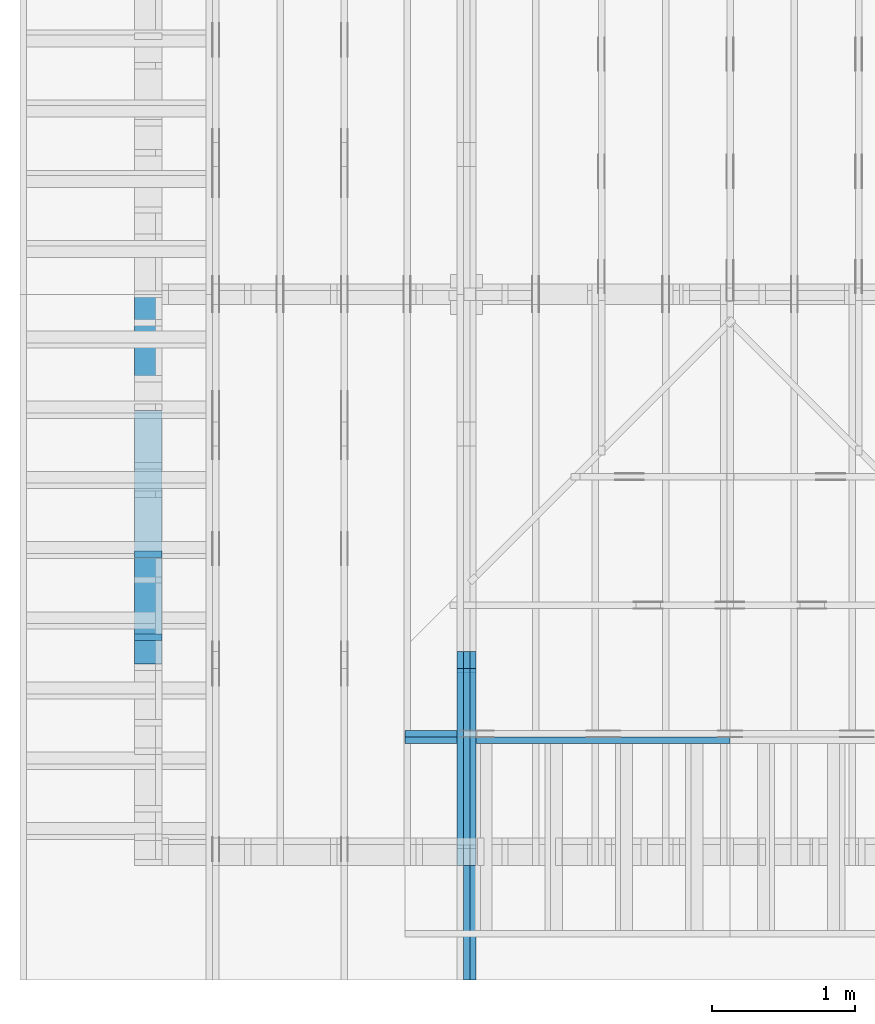
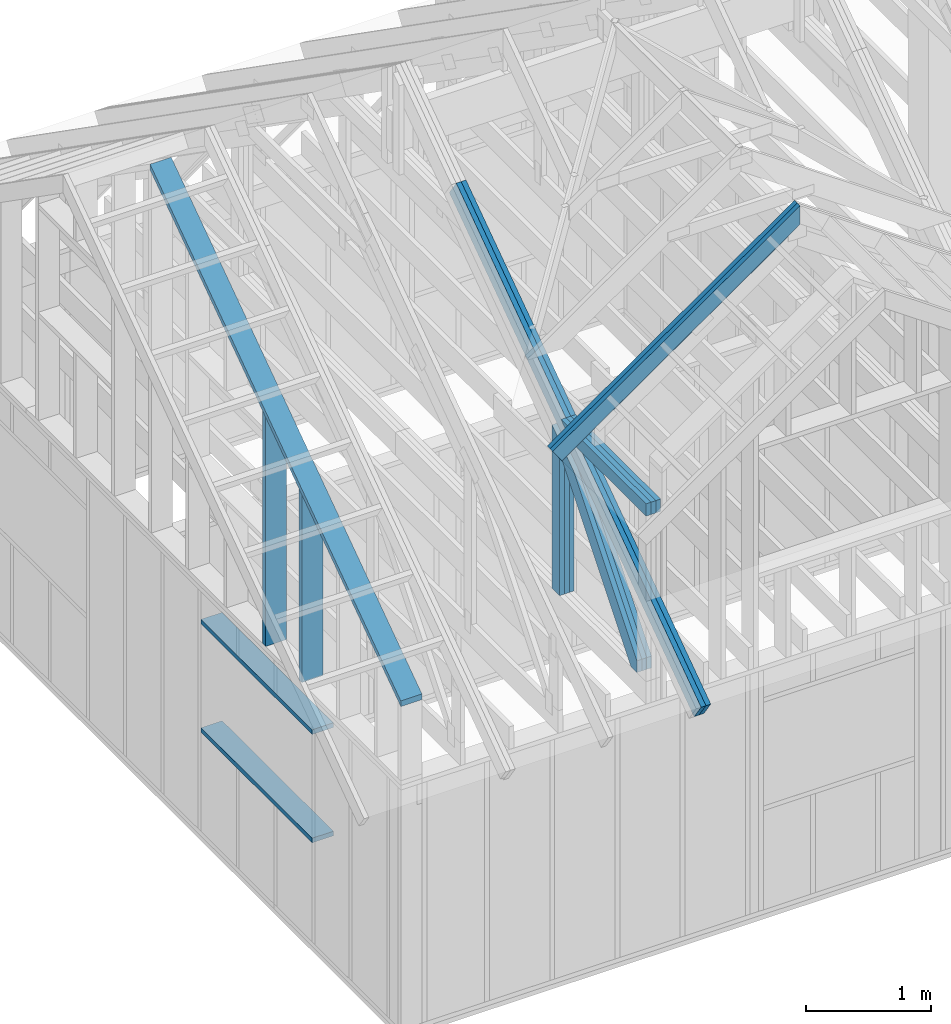
# One storey, part 4 of 70: 18 members, 5 elements without a shape of their own.
"""IFC2X3 building model written with IfcOpenShell, lengths in millimetres."""

from ifc_helpers import new_model, si_unit, frame, origin, origin_with_axes, origin_2d, place, context, project, spatial, faceted_brep, element, aggregate, save


model = new_model("IFC2X3")

# Units and contexts
model_context = context("Model", 3, precision=1e-05, world=origin())
plan_context = context("Plan", 2, precision=1e-05, world=origin_2d())
ifc_project = project(units=[si_unit("LENGTHUNIT", "METRE", prefix="MILLI"), si_unit("AREAUNIT", "SQUARE_METRE"), si_unit("VOLUMEUNIT", "CUBIC_METRE"), si_unit("SOLIDANGLEUNIT", "STERADIAN"), si_unit("PLANEANGLEUNIT", "RADIAN"), si_unit("MASSUNIT", "GRAM"), si_unit("TIMEUNIT", "SECOND"), si_unit("THERMODYNAMICTEMPERATUREUNIT", "DEGREE_CELSIUS"), si_unit("LUMINOUSINTENSITYUNIT", "LUMEN")], contexts=[model_context, plan_context])

# Site, building, storey
site_placement = place(None, origin_with_axes())
site = spatial("IfcSite", under=ifc_project, at=site_placement, CompositionType="ELEMENT")
building_placement = place(site_placement, origin_with_axes())
building = spatial("IfcBuilding", under=site, at=building_placement, Name="Layout 1", CompositionType="ELEMENT")
storey_placement = place(building_placement, origin_with_axes())
storey = spatial("IfcBuildingStorey", under=building, at=storey_placement, Name="Storey 1", CompositionType="ELEMENT", Elevation=0.0)

# Assembly, members
assembly_1_placement = place(storey_placement, frame((1969.9999999999982, 8000.000000000001, 1.1021457184401395e-14), z_axis=(-1.0, 1.836909530733566e-16, 6.123031769111886e-17), x_axis=(-1.836909530733566e-16, -1.0, 0.0)))
assembly_1 = element("IfcElementAssembly", 1, at=assembly_1_placement, inside=storey, Name="T11", AssemblyPlace="FACTORY", PredefinedType="TRUSS")
member_1_placement = place(assembly_1_placement, frame((4782.309641268, 3014.9999999994516, -135.0), z_axis=(0.0, 0.0, 1.0), x_axis=(0.8191520442889916, -0.5735764363510465, 0.0)))
member_1 = element("IfcMember", 2, at=member_1_placement, Name="T9", context=model_context, shape_type="Brep", body=[
    faceted_brep([(4768.153825500908, 195.00000000180353, 45.0), (1.6370904631912708e-10, 195.00000000180353, 45.0), (0.0, 1.8071659724228084e-09, 45.0), (4768.153825500287, 1.8071659724228084e-09, 45.0), (1.6370904631912708e-10, 195.00000000180353, 2.004791383006049e-26), (4768.153825500908, 195.00000000180353, 5.839111470710887e-13), (4768.153825500287, 1.8071659724228084e-09, 5.839111470710126e-13), (0.0, 1.8071659724228084e-09, 0.0), (-1.2523674699591298e-25, 1.8071659724228084e-09, 7.668285805162028e-42), (2.755364295975112e-15, 1.8071659724228084e-09, 45.0), (1.636957134777711e-10, 195.000000001015, 45.0), (1.63692958113475e-10, 195.000000001015, 9.850859431565386e-31), (4768.153825500287, -2.042652045517506e-12, 1.250722336794479e-28), (4768.153825500287, -2.039896681221406e-12, 45.0), (1.0454840658689129e-27, 1.8071687277871045e-09, 45.0), (0.0, 1.8071659724228084e-09, 0.0), (4768.153825500287, 195.00000000180353, -3.8067271842345146e-26), (4768.153825500287, 195.00000000180353, 45.0), (4768.153825500287, 0.0, 45.0), (4768.153825500287, 0.0, 0.0), (1.6370904631912708e-10, 195.000000001015, 0.0), (1.6370904631912708e-10, 195.000000001015, 45.0), (4768.153825500908, 195.00000000180347, 45.0), (4768.153825500908, 195.00000000180347, -4.733165431326071e-30)], [[[0, 1, 2, 3]], [[4, 5, 6, 7]], [[8, 9, 10, 11]], [[12, 13, 14, 15]], [[16, 17, 18, 19]], [[20, 21, 22, 23]]]),
])
member_2_placement = place(assembly_1_placement, frame((4782.309641268, 3014.9999999994516, -180.00000000000003), z_axis=(0.0, 0.0, 1.0), x_axis=(0.8191520442889916, -0.5735764363510465, 0.0)))
member_2 = element("IfcMember", 3, at=member_2_placement, Name="T9", context=model_context, shape_type="Brep", body=[
    faceted_brep([(4768.153825500908, 195.00000000180353, 45.0), (1.6370904631912708e-10, 195.00000000180353, 45.0), (0.0, 1.8071659724228084e-09, 45.0), (4768.153825500287, 1.8071659724228084e-09, 45.0), (1.6370904631912708e-10, 195.00000000180353, 2.004791383006049e-26), (4768.153825500908, 195.00000000180353, 5.839111470710887e-13), (4768.153825500287, 1.8071659724228084e-09, 5.839111470710126e-13), (0.0, 1.8071659724228084e-09, 0.0), (-1.2523674699591298e-25, 1.8071659724228084e-09, 7.668285805162028e-42), (2.755364295975112e-15, 1.8071659724228084e-09, 45.0), (1.636957134777711e-10, 195.000000001015, 45.0), (1.63692958113475e-10, 195.000000001015, 9.850859431565386e-31), (4768.153825500287, -2.042652045517506e-12, 1.250722336794479e-28), (4768.153825500287, -2.039896681221406e-12, 45.0), (1.0454840658689129e-27, 1.8071687277871045e-09, 45.0), (0.0, 1.8071659724228084e-09, 0.0), (4768.153825500287, 195.00000000180353, -3.8067271842345146e-26), (4768.153825500287, 195.00000000180353, 45.0), (4768.153825500287, 0.0, 45.0), (4768.153825500287, 0.0, 0.0), (1.6370904631912708e-10, 195.000000001015, 0.0), (1.6370904631912708e-10, 195.000000001015, 45.0), (4768.153825500908, 195.00000000180347, 45.0), (4768.153825500908, 195.00000000180347, -4.733165431326071e-30)], [[[0, 1, 2, 3]], [[4, 5, 6, 7]], [[8, 9, 10, 11]], [[12, 13, 14, 15]], [[16, 17, 18, 19]], [[20, 21, 22, 23]]]),
])
member_3_placement = place(assembly_1_placement, frame((6619.9999999949505, 219.99999999999994, -90.0), z_axis=(0.0, 0.0, 1.0), x_axis=(5.053195275411815e-16, 1.0, 0.0)))
member_3 = element("IfcMember", 4, at=member_3_placement, Name="R1", context=model_context, shape_type="Brep", body=[
    faceted_brep([(1592.2602625099316, 120.00000000000091, 45.0), (0.0, 120.00000000000091, 45.0), (5.684341886080802e-14, 0.0, 45.0), (1508.2353579246992, 0.0, 45.0), (0.0, 120.00000000000091, 0.0), (1592.2602625099316, 120.00000000000091, 1.9498920344085486e-13), (1508.2353579246992, 0.0, 1.846994602374154e-13), (5.684341886080802e-14, 0.0, 6.961081190993225e-30), (5.684341886080802e-14, 0.0, 0.0), (5.959878315690836e-14, 8.86203890694297e-31, 45.0), (2.1003354220769377e-14, 120.0, 45.0), (1.8247989924669028e-14, 120.0, -1.1173302203118208e-30), (1508.2353579246992, -2.7704919035612314e-13, 7.265245946951848e-29), (1508.2353579246992, -2.742938260600228e-13, 45.0), (5.684341886080802e-14, 2.7553642961003043e-15, 45.0), (5.684341886080802e-14, -4.4719288075722504e-29, 2.7381762157971524e-45), (1592.260262509932, 120.00000000000057, 1.9009198412843567e-29), (1592.260262509932, 120.00000000000057, 45.0), (1508.2353579246997, 6.821210263296962e-13, 45.0), (1508.2353579246997, 6.821210263296962e-13, 3.2533805409343593e-29), (0.0, 120.0, 0.0), (0.0, 120.0, 45.0), (1592.2602625099316, 120.00000000000131, 45.0), (1592.2602625099316, 120.00000000000132, 2.524354896707238e-29)], [[[0, 1, 2, 3]], [[4, 5, 6, 7]], [[8, 9, 10, 11]], [[12, 13, 14, 15]], [[16, 17, 18, 19]], [[20, 21, 22, 23]]]),
])
member_4_placement = place(assembly_1_placement, frame((6619.9999999949505, 219.99999999999994, -135.0), z_axis=(0.0, 0.0, 1.0), x_axis=(5.053195275411815e-16, 1.0, 0.0)))
member_4 = element("IfcMember", 5, at=member_4_placement, Name="R1", context=model_context, shape_type="Brep", body=[
    faceted_brep([(1592.2602625099316, 120.00000000000091, 45.0), (0.0, 120.00000000000091, 45.0), (5.684341886080802e-14, 0.0, 45.0), (1508.2353579246992, 0.0, 45.0), (0.0, 120.00000000000091, 0.0), (1592.2602625099316, 120.00000000000091, 1.9498920344085486e-13), (1508.2353579246992, 0.0, 1.846994602374154e-13), (5.684341886080802e-14, 0.0, 6.961081190993225e-30), (5.684341886080802e-14, 0.0, 0.0), (5.959878315690836e-14, 8.86203890694297e-31, 45.0), (2.1003354220769377e-14, 120.0, 45.0), (1.8247989924669028e-14, 120.0, -1.1173302203118208e-30), (1508.2353579246992, -2.7704919035612314e-13, 7.265245946951848e-29), (1508.2353579246992, -2.742938260600228e-13, 45.0), (5.684341886080802e-14, 2.7553642961003043e-15, 45.0), (5.684341886080802e-14, -4.4719288075722504e-29, 2.7381762157971524e-45), (1592.260262509932, 120.00000000000057, 1.9009198412843567e-29), (1592.260262509932, 120.00000000000057, 45.0), (1508.2353579246997, 6.821210263296962e-13, 45.0), (1508.2353579246997, 6.821210263296962e-13, 3.2533805409343593e-29), (0.0, 120.0, 0.0), (0.0, 120.0, 45.0), (1592.2602625099316, 120.00000000000131, 45.0), (1592.2602625099316, 120.00000000000132, 2.524354896707238e-29)], [[[0, 1, 2, 3]], [[4, 5, 6, 7]], [[8, 9, 10, 11]], [[12, 13, 14, 15]], [[16, 17, 18, 19]], [[20, 21, 22, 23]]]),
])
member_5_placement = place(assembly_1_placement, frame((6619.9999999949505, 219.99999999999994, -180.0), z_axis=(0.0, 0.0, 1.0), x_axis=(5.053195275411815e-16, 1.0, 0.0)))
member_5 = element("IfcMember", 6, at=member_5_placement, Name="R1", context=model_context, shape_type="Brep", body=[
    faceted_brep([(1592.2602625099316, 120.00000000000091, 45.0), (0.0, 120.00000000000091, 45.0), (5.684341886080802e-14, 0.0, 45.0), (1508.2353579246992, 0.0, 45.0), (0.0, 120.00000000000091, 0.0), (1592.2602625099316, 120.00000000000091, 1.9498920344085486e-13), (1508.2353579246992, 0.0, 1.846994602374154e-13), (5.684341886080802e-14, 0.0, 6.961081190993225e-30), (5.684341886080802e-14, 0.0, 0.0), (5.959878315690836e-14, 8.86203890694297e-31, 45.0), (2.1003354220769377e-14, 120.0, 45.0), (1.8247989924669028e-14, 120.0, -1.1173302203118208e-30), (1508.2353579246992, -2.7704919035612314e-13, 7.265245946951848e-29), (1508.2353579246992, -2.742938260600228e-13, 45.0), (5.684341886080802e-14, 2.7553642961003043e-15, 45.0), (5.684341886080802e-14, -4.4719288075722504e-29, 2.7381762157971524e-45), (1592.260262509932, 120.00000000000057, 1.9009198412843567e-29), (1592.260262509932, 120.00000000000057, 45.0), (1508.2353579246997, 6.821210263296962e-13, 45.0), (1508.2353579246997, 6.821210263296962e-13, 3.2533805409343593e-29), (0.0, 120.0, 0.0), (0.0, 120.0, 45.0), (1592.2602625099316, 120.00000000000131, 45.0), (1592.2602625099316, 120.00000000000132, 2.524354896707238e-29)], [[[0, 1, 2, 3]], [[4, 5, 6, 7]], [[8, 9, 10, 11]], [[12, 13, 14, 15]], [[16, 17, 18, 19]], [[20, 21, 22, 23]]]),
])
member_6_placement = place(assembly_1_placement, frame((6563.906131857986, 1682.303582896796, -90.00000000000001), z_axis=(0.0, 0.0, 1.0), x_axis=(0.6335417245359882, -0.7737085260432164, 0.0)))
member_6 = element("IfcMember", 7, at=member_6_placement, Name="W6", context=model_context, shape_type="Brep", body=[
    faceted_brep([(1860.8184531642582, 145.00000000000364, 45.0), (258.1329393215924, 145.00000000000364, 45.0), (0.0, 72.49999999849206, 45.0), (88.54013234574177, 0.0, 45.0), (1889.9928508932062, 0.0, 45.0), (1949.358585511326, 72.49999999849206, 45.0), (258.1329393215924, 145.00000000000364, 3.1611123762406824e-14), (1860.8184531642582, 145.00000000000364, 2.2787701010548785e-13), (1949.358585511326, 72.49999999849206, 2.3871969096953717e-13), (1889.9928508932062, 0.0, 2.3144972538826894e-13), (88.54013234574177, 0.0, 1.0842680863886955e-14), (0.0, 72.49999999849206, 0.0), (7.105427357601002e-15, 72.49999999849206, 1.7516230804060213e-46), (7.105427357601002e-15, 72.49999999849206, 45.0), (258.13293932159246, 145.0, 45.0), (258.13293932159246, 145.0, 1.7516230804060213e-46), (88.54013234574177, -2.842170943040401e-14, 2.3665827156630354e-30), (88.54013234574177, -2.842170943040401e-14, 45.0), (7.105427357601002e-15, 72.49999999849209, 45.0), (7.105427357601002e-15, 72.49999999849209, -1.1832913578315177e-30), (1889.9928508932062, 2.7866220188636956e-12, 1.0781749613963793e-28), (1889.9928508932062, 2.789377383159796e-12, 45.0), (88.54013234574177, -7.973490750159428e-14, 45.0), (88.54013234574177, -8.249027179769463e-14, 5.0509055485995835e-30), (1949.358585511326, 72.50000000000239, 1.262177448353619e-29), (1949.358585511326, 72.50000000000239, 45.0), (1889.9928508932062, 4.206412995699793e-12, 45.0), (1889.9928508932062, 4.206412995699793e-12, 1.262177448353619e-29), (1860.8184531642582, 145.00000000000364, -1.262177448353619e-29), (1860.8184531642582, 145.00000000000364, 45.0), (1949.358585511326, 72.50000000000261, 45.0), (1949.358585511326, 72.50000000000261, -1.262177448353619e-29), (258.1329393215924, 144.99999999999997, -1.5777218104420236e-30), (258.1329393215924, 144.99999999999997, 45.0), (1860.8184531642582, 145.0000000000034, 45.0), (1860.8184531642582, 145.0000000000034, -1.262177448353619e-29)], [[[0, 1, 2, 3, 4, 5]], [[6, 7, 8, 9, 10, 11]], [[12, 13, 14, 15]], [[16, 17, 18, 19]], [[20, 21, 22, 23]], [[24, 25, 26, 27]], [[28, 29, 30, 31]], [[32, 33, 34, 35]]]),
])
member_7_placement = place(assembly_1_placement, frame((6563.906131857986, 1682.303582896796, -135.00000000000003), z_axis=(0.0, 0.0, 1.0), x_axis=(0.6335417245359882, -0.7737085260432164, 0.0)))
member_7 = element("IfcMember", 8, at=member_7_placement, Name="W6", context=model_context, shape_type="Brep", body=[
    faceted_brep([(1860.8184531642582, 145.00000000000364, 45.0), (258.1329393215924, 145.00000000000364, 45.0), (0.0, 72.49999999849206, 45.0), (88.54013234574177, 0.0, 45.0), (1889.9928508932062, 0.0, 45.0), (1949.358585511326, 72.49999999849206, 45.0), (258.1329393215924, 145.00000000000364, 3.1611123762406824e-14), (1860.8184531642582, 145.00000000000364, 2.2787701010548785e-13), (1949.358585511326, 72.49999999849206, 2.3871969096953717e-13), (1889.9928508932062, 0.0, 2.3144972538826894e-13), (88.54013234574177, 0.0, 1.0842680863886955e-14), (0.0, 72.49999999849206, 0.0), (7.105427357601002e-15, 72.49999999849206, 1.7516230804060213e-46), (7.105427357601002e-15, 72.49999999849206, 45.0), (258.13293932159246, 145.0, 45.0), (258.13293932159246, 145.0, 1.7516230804060213e-46), (88.54013234574177, -2.842170943040401e-14, 2.3665827156630354e-30), (88.54013234574177, -2.842170943040401e-14, 45.0), (7.105427357601002e-15, 72.49999999849209, 45.0), (7.105427357601002e-15, 72.49999999849209, -1.1832913578315177e-30), (1889.9928508932062, 2.7866220188636956e-12, 1.0781749613963793e-28), (1889.9928508932062, 2.789377383159796e-12, 45.0), (88.54013234574177, -7.973490750159428e-14, 45.0), (88.54013234574177, -8.249027179769463e-14, 5.0509055485995835e-30), (1949.358585511326, 72.50000000000239, 1.262177448353619e-29), (1949.358585511326, 72.50000000000239, 45.0), (1889.9928508932062, 4.206412995699793e-12, 45.0), (1889.9928508932062, 4.206412995699793e-12, 1.262177448353619e-29), (1860.8184531642582, 145.00000000000364, -1.262177448353619e-29), (1860.8184531642582, 145.00000000000364, 45.0), (1949.358585511326, 72.50000000000261, 45.0), (1949.358585511326, 72.50000000000261, -1.262177448353619e-29), (258.1329393215924, 144.99999999999997, -1.5777218104420236e-30), (258.1329393215924, 144.99999999999997, 45.0), (1860.8184531642582, 145.0000000000034, 45.0), (1860.8184531642582, 145.0000000000034, -1.262177448353619e-29)], [[[0, 1, 2, 3, 4, 5]], [[6, 7, 8, 9, 10, 11]], [[12, 13, 14, 15]], [[16, 17, 18, 19]], [[20, 21, 22, 23]], [[24, 25, 26, 27]], [[28, 29, 30, 31]], [[32, 33, 34, 35]]]),
])
member_8_placement = place(assembly_1_placement, frame((6563.906131857986, 1682.303582896796, -180.00000000000003), z_axis=(0.0, 0.0, 1.0), x_axis=(0.6335417245359882, -0.7737085260432164, 0.0)))
member_8 = element("IfcMember", 9, at=member_8_placement, Name="W6", context=model_context, shape_type="Brep", body=[
    faceted_brep([(1860.8184531642582, 145.00000000000364, 45.0), (258.1329393215924, 145.00000000000364, 45.0), (0.0, 72.49999999849206, 45.0), (88.54013234574177, 0.0, 45.0), (1889.9928508932062, 0.0, 45.0), (1949.358585511326, 72.49999999849206, 45.0), (258.1329393215924, 145.00000000000364, 3.1611123762406824e-14), (1860.8184531642582, 145.00000000000364, 2.2787701010548785e-13), (1949.358585511326, 72.49999999849206, 2.3871969096953717e-13), (1889.9928508932062, 0.0, 2.3144972538826894e-13), (88.54013234574177, 0.0, 1.0842680863886955e-14), (0.0, 72.49999999849206, 0.0), (7.105427357601002e-15, 72.49999999849206, 1.7516230804060213e-46), (7.105427357601002e-15, 72.49999999849206, 45.0), (258.13293932159246, 145.0, 45.0), (258.13293932159246, 145.0, 1.7516230804060213e-46), (88.54013234574177, -2.842170943040401e-14, 2.3665827156630354e-30), (88.54013234574177, -2.842170943040401e-14, 45.0), (7.105427357601002e-15, 72.49999999849209, 45.0), (7.105427357601002e-15, 72.49999999849209, -1.1832913578315177e-30), (1889.9928508932062, 2.7866220188636956e-12, 1.0781749613963793e-28), (1889.9928508932062, 2.789377383159796e-12, 45.0), (88.54013234574177, -7.973490750159428e-14, 45.0), (88.54013234574177, -8.249027179769463e-14, 5.0509055485995835e-30), (1949.358585511326, 72.50000000000239, 1.262177448353619e-29), (1949.358585511326, 72.50000000000239, 45.0), (1889.9928508932062, 4.206412995699793e-12, 45.0), (1889.9928508932062, 4.206412995699793e-12, 1.262177448353619e-29), (1860.8184531642582, 145.00000000000364, -1.262177448353619e-29), (1860.8184531642582, 145.00000000000364, 45.0), (1949.358585511326, 72.50000000000261, 45.0), (1949.358585511326, 72.50000000000261, -1.262177448353619e-29), (258.1329393215924, 144.99999999999997, -1.5777218104420236e-30), (258.1329393215924, 144.99999999999997, 45.0), (1860.8184531642582, 145.0000000000034, 45.0), (1860.8184531642582, 145.0000000000034, -1.262177448353619e-29)], [[[0, 1, 2, 3, 4, 5]], [[6, 7, 8, 9, 10, 11]], [[12, 13, 14, 15]], [[16, 17, 18, 19]], [[20, 21, 22, 23]], [[24, 25, 26, 27]], [[28, 29, 30, 31]], [[32, 33, 34, 35]]]),
])
member_9_placement = place(assembly_1_placement, frame((8000.000000000239, 1950.43961597234, -90.0), z_axis=(0.0, 0.0, 1.0), x_axis=(-1.0, -7.792541026514777e-13, 0.0)))
member_9 = element("IfcMember", 10, at=member_9_placement, Name="T20", context=model_context, shape_type="Brep", body=[
    faceted_brep([(1185.9906822582107, 120.00000000718114, 45.0), (0.0, 120.00000000718114, 45.0), (2.3919710656628013e-10, 0.0, 45.0), (1357.3684430670319, 0.0, 45.0), (0.0, 120.00000000718114, 0.0), (1185.9906822582107, 120.00000000718114, 1.452371725067541e-13), (1357.3684430670319, 0.0, 1.662242019857875e-13), (2.3919710656628013e-10, 0.0, 2.929222965169949e-26), (2.3919710656628013e-10, 0.0, 0.0), (2.3919986193057623e-10, 5.491303034653426e-27, 45.0), (4.5872349972372883e-14, 120.0, 45.0), (4.3116985676272535e-14, 120.0, -2.6400667308415888e-30), (1357.3684430670319, 7.185039401631766e-09, 5.377473518020143e-29), (1357.3684430670319, 7.185042156996062e-09, 45.0), (2.3919710656628013e-10, 2.755364295945585e-15, 45.0), (2.3919710656628013e-10, -1.5476399835663503e-25, 9.476248786526727e-42), (1185.9906822582107, 120.00000000718126, 7.47707513912535e-31), (1185.9906822582107, 120.00000000718126, 45.0), (1357.3684430670319, 7.185803951870184e-09, 45.0), (1357.3684430670319, 7.185803951870184e-09, -5.4167093989721165e-31), (0.0, 120.0, 0.0), (0.0, 120.0, 45.0), (1185.9906822582107, 120.00000000718101, 45.0), (1185.9906822582107, 120.00000000718103, -6.310887241768095e-30)], [[[0, 1, 2, 3]], [[4, 5, 6, 7]], [[8, 9, 10, 11]], [[12, 13, 14, 15]], [[16, 17, 18, 19]], [[20, 21, 22, 23]]]),
])
member_10_placement = place(assembly_1_placement, frame((8000.000000000239, 1950.43961597234, -135.0), z_axis=(0.0, 0.0, 1.0), x_axis=(-1.0, -7.792541026514777e-13, 0.0)))
member_10 = element("IfcMember", 11, at=member_10_placement, Name="T20", context=model_context, shape_type="Brep", body=[
    faceted_brep([(1185.9906822582107, 120.00000000718114, 45.0), (0.0, 120.00000000718114, 45.0), (2.3919710656628013e-10, 0.0, 45.0), (1357.3684430670319, 0.0, 45.0), (0.0, 120.00000000718114, 0.0), (1185.9906822582107, 120.00000000718114, 1.452371725067541e-13), (1357.3684430670319, 0.0, 1.662242019857875e-13), (2.3919710656628013e-10, 0.0, 2.929222965169949e-26), (2.3919710656628013e-10, 0.0, 0.0), (2.3919986193057623e-10, 5.491303034653426e-27, 45.0), (4.5872349972372883e-14, 120.0, 45.0), (4.3116985676272535e-14, 120.0, -2.6400667308415888e-30), (1357.3684430670319, 7.185039401631766e-09, 5.377473518020143e-29), (1357.3684430670319, 7.185042156996062e-09, 45.0), (2.3919710656628013e-10, 2.755364295945585e-15, 45.0), (2.3919710656628013e-10, -1.5476399835663503e-25, 9.476248786526727e-42), (1185.9906822582107, 120.00000000718126, 7.47707513912535e-31), (1185.9906822582107, 120.00000000718126, 45.0), (1357.3684430670319, 7.185803951870184e-09, 45.0), (1357.3684430670319, 7.185803951870184e-09, -5.4167093989721165e-31), (0.0, 120.0, 0.0), (0.0, 120.0, 45.0), (1185.9906822582107, 120.00000000718101, 45.0), (1185.9906822582107, 120.00000000718103, -6.310887241768095e-30)], [[[0, 1, 2, 3]], [[4, 5, 6, 7]], [[8, 9, 10, 11]], [[12, 13, 14, 15]], [[16, 17, 18, 19]], [[20, 21, 22, 23]]]),
])
member_11_placement = place(assembly_1_placement, frame((8000.000000000239, 1950.43961597234, -180.0), z_axis=(0.0, 0.0, 1.0), x_axis=(-1.0, -7.792541026514777e-13, 0.0)))
member_11 = element("IfcMember", 12, at=member_11_placement, Name="T20", context=model_context, shape_type="Brep", body=[
    faceted_brep([(1185.9906822582107, 120.00000000718114, 45.0), (0.0, 120.00000000718114, 45.0), (2.3919710656628013e-10, 0.0, 45.0), (1357.3684430670319, 0.0, 45.0), (0.0, 120.00000000718114, 0.0), (1185.9906822582107, 120.00000000718114, 1.452371725067541e-13), (1357.3684430670319, 0.0, 1.662242019857875e-13), (2.3919710656628013e-10, 0.0, 2.929222965169949e-26), (2.3919710656628013e-10, 0.0, 0.0), (2.3919986193057623e-10, 5.491303034653426e-27, 45.0), (4.5872349972372883e-14, 120.0, 45.0), (4.3116985676272535e-14, 120.0, -2.6400667308415888e-30), (1357.3684430670319, 7.185039401631766e-09, 5.377473518020143e-29), (1357.3684430670319, 7.185042156996062e-09, 45.0), (2.3919710656628013e-10, 2.755364295945585e-15, 45.0), (2.3919710656628013e-10, -1.5476399835663503e-25, 9.476248786526727e-42), (1185.9906822582107, 120.00000000718126, 7.47707513912535e-31), (1185.9906822582107, 120.00000000718126, 45.0), (1357.3684430670319, 7.185803951870184e-09, 45.0), (1357.3684430670319, 7.185803951870184e-09, -5.4167093989721165e-31), (0.0, 120.0, 0.0), (0.0, 120.0, 45.0), (1185.9906822582107, 120.00000000718101, 45.0), (1185.9906822582107, 120.00000000718103, -6.310887241768095e-30)], [[[0, 1, 2, 3]], [[4, 5, 6, 7]], [[8, 9, 10, 11]], [[12, 13, 14, 15]], [[16, 17, 18, 19]], [[20, 21, 22, 23]]]),
])
aggregate(assembly_1, [member_1, member_2, member_3, member_4, member_5, member_6, member_7, member_8, member_9, member_10, member_11])

# Assembly, member
assembly_2_placement = place(storey_placement, frame((6205.00000000017, 945.0, 1.3776821480501744e-15), z_axis=(1.2246063538223773e-16, 1.0, 6.123031769111886e-17), x_axis=(-1.0, 1.2246063538223773e-16, 0.0)))
assembly_2 = element("IfcElementAssembly", 13, at=assembly_2_placement, inside=storey, Name="T7", AssemblyPlace="FACTORY", PredefinedType="TRUSS")
member_12_placement = place(assembly_2_placement, frame((2165.652594910139, 3504.8842505317025, -45.00000000000001), z_axis=(0.0, 0.0, 1.0), x_axis=(0.8191520442889916, -0.5735764363510465, 0.0)))
member_12 = element("IfcMember", 14, at=member_12_placement, Name="T14", context=model_context, shape_type="Brep", body=[
    faceted_brep([(2780.314125905581, 195.00000000050568, 45.0), (0.0, 195.00000000050568, 45.0), (136.54046995208637, 1.0486473911441863e-09, 45.0), (2780.314125905188, 1.0486473911441863e-09, 45.0), (0.0, 195.00000000050568, 0.0), (2780.314125905581, 195.00000000050568, 3.4047903442060836e-13), (2780.314125905188, 1.0486473911441863e-09, 3.4047903442056024e-13), (136.54046995208637, 1.0486473911441863e-09, 1.6720832705721834e-14), (136.54046995208634, 1.048633180289471e-09, 2.060383866519029e-30), (136.54046995208634, 1.048633180289471e-09, 45.0), (0.0, 195.00000000275122, 45.0), (0.0, 195.00000000275122, -1.9557987228064122e-31), (2780.314125905188, -1.5333383701817237e-12, 9.388679553421215e-29), (2780.314125905188, -1.5305830058856234e-12, 45.0), (136.54046995208637, 1.0485748446784807e-09, 45.0), (136.54046995208637, 1.0485720893141846e-09, 4.610754973720203e-30), (2780.314125905188, 195.00000000050568, -2.4057102165619976e-26), (2780.314125905188, 195.00000000050568, 45.0), (2780.314125905188, 0.0, 45.0), (2780.314125905188, 0.0, 0.0), (0.0, 195.00000000275122, 0.0), (0.0, 195.00000000275122, 45.0), (2780.314125905581, 195.00000000050574, 45.0), (2780.314125905581, 195.00000000050574, 3.1554436208840472e-30)], [[[0, 1, 2, 3]], [[4, 5, 6, 7]], [[8, 9, 10, 11]], [[12, 13, 14, 15]], [[16, 17, 18, 19]], [[20, 21, 22, 23]]]),
])
aggregate(assembly_2, [member_12])

# Assembly, members
assembly_3_placement = place(storey_placement, frame((-243.55339059327574, 8000.000000000001, -2470.0), z_axis=(-1.0, 1.836909530733566e-16, 6.123031769111886e-17), x_axis=(-1.836909530733566e-16, -1.0, 0.0)))
assembly_3 = element("IfcElementAssembly", 15, at=assembly_3_placement, inside=storey, Name="VE3", AssemblyPlace="FACTORY", PredefinedType="NOTDEFINED")
member_13_placement = place(assembly_3_placement, frame((6587.5000000018335, 2154.9999999987776, -195.0), z_axis=(0.0, 0.0, 1.0), x_axis=(-1.0, 1.2246063538223773e-16, 0.0)))
member_13 = element("IfcMember", 16, at=member_13_placement, Name="S17", context=model_context, shape_type="Brep", body=[
    faceted_brep([(1775.0000000000146, 45.00000000001501, 195.0), (0.0, 45.00000000001501, 195.0), (0.0, 0.0, 195.0), (1775.0000000000146, 0.0, 195.0), (0.0, 45.00000000001501, 0.0), (1775.0000000000146, 45.00000000001501, 2.1736762780347376e-13), (1775.0000000000146, 0.0, 2.1736762780347376e-13), (0.0, 0.0, 0.0), (0.0, 0.0, 0.0), (1.1939911949768178e-14, -1.462169203776584e-30, 195.0), (1.745064054197066e-14, 45.00000000001455, 195.0), (5.51072859220248e-15, 45.00000000001455, -3.3742366241009005e-31), (1775.0000000000146, -3.260514417052106e-13, 4.780855812323027e-29), (1775.0000000000146, -3.1411152975544244e-13, 195.0), (2.193253805664876e-30, 1.1939911949768178e-14, 195.0), (0.0, 0.0, 0.0), (1775.0000000000146, 45.00000000001501, 0.0), (1775.0000000000146, 45.00000000001501, 195.0), (1775.0000000000146, 4.547473508864641e-13, 195.0), (1775.0000000000146, 4.547473508864641e-13, 0.0), (0.0, 45.00000000001455, 0.0), (1.5777218104420236e-30, 45.00000000001454, 195.0), (1775.0000000000146, 45.00000000001482, 195.0), (1775.0000000000146, 45.000000000014836, -1.064962222048366e-29)], [[[0, 1, 2, 3]], [[4, 5, 6, 7]], [[8, 9, 10, 11]], [[12, 13, 14, 15]], [[16, 17, 18, 19]], [[20, 21, 22, 23]]]),
])
member_14_placement = place(assembly_3_placement, frame((4812.500000001819, 1055.0, -195.0), z_axis=(0.0, 0.0, 1.0), x_axis=(1.0, 0.0, 0.0)))
member_14 = element("IfcMember", 17, at=member_14_placement, Name="S17", context=model_context, shape_type="Brep", body=[
    faceted_brep([(1775.0000000000146, 45.0, 195.0), (0.0, 45.0, 195.0), (0.0, 0.0, 195.0), (1775.0000000000146, 0.0, 195.0), (0.0, 45.0, 0.0), (1775.0000000000146, 45.0, 2.1736762780347376e-13), (1775.0000000000146, 0.0, 2.1736762780347376e-13), (0.0, 0.0, 0.0), (0.0, 0.0, 0.0), (1.1939911949768178e-14, -1.462169203776584e-30, 195.0), (1.7450640541968876e-14, 45.0, 195.0), (5.510728592200698e-15, 45.0, -3.3742366240998092e-31), (1775.0000000000146, -3.260514417052106e-13, 1.9964233359257367e-29), (1775.0000000000146, -3.1411152975544244e-13, 195.0), (2.193253805664876e-30, 1.1939911949768178e-14, 195.0), (0.0, 0.0, 0.0), (1775.0000000000146, 45.0, 0.0), (1775.0000000000146, 45.0, 195.0), (1775.0000000000146, 0.0, 195.0), (1775.0000000000146, 0.0, 0.0), (0.0, 45.0, 0.0), (-7.31084601888292e-31, 44.999999999999986, 195.0), (1775.0000000000146, 44.99999999999988, 195.0), (1775.0000000000146, 44.99999999999989, -6.7053176943786e-30)], [[[0, 1, 2, 3]], [[4, 5, 6, 7]], [[8, 9, 10, 11]], [[12, 13, 14, 15]], [[16, 17, 18, 19]], [[20, 21, 22, 23]]]),
])
aggregate(assembly_3, [member_13, member_14])

assembly_4_placement = place(storey_placement, frame((-48.55339059327645, 2.2546681725408788e-11, 1.1939911949768178e-14), z_axis=(1.0, 1.156240088482502e-13, 6.123031769111886e-17), x_axis=(-1.156240088482502e-13, 1.0, 0.0)))
assembly_4 = element("IfcElementAssembly", 18, at=assembly_4_placement, inside=storey, Name="VEg1", AssemblyPlace="FACTORY", PredefinedType="NOTDEFINED")
member_15_placement = place(assembly_4_placement, frame((1.1311840353300798e-11, 768.0528281349691, -195.00000000000006), z_axis=(0.0, 0.0, 1.0), x_axis=(0.819152044288992, 0.5735764363510462, 0.0)))
member_15 = element("IfcMember", 19, at=member_15_placement, Name="P6", context=model_context, shape_type="Brep", body=[
    faceted_brep([(4914.607694265944, 45.00000000099453, 195.0), (31.509339219794356, 45.00000000099453, 195.0), (0.0, 0.0, 195.0), (4883.098355046151, 0.0, 195.0), (31.509339219794356, 45.00000000099453, 3.858653701330479e-15), (4914.607694265944, 45.00000000099453, 6.018459808942418e-13), (4883.098355046151, 0.0, 5.979873271929115e-13), (0.0, 0.0, 0.0), (0.0, 0.0, 0.0), (9.780603282283166e-15, -6.848452146493301e-15, 195.0), (31.509339219794363, 45.000000000510454, 195.0), (31.509339219794352, 45.00000000051046, 1.9721522630525295e-31), (4883.098355046151, 4.848540279944298e-10, -8.924894381438143e-29), (4883.098355046151, 4.848659679063795e-10, 195.0), (-1.1855412244075542e-27, 1.1939911949768178e-14, 195.0), (0.0, 0.0, 0.0), (4914.607694265946, 45.00000000099317, 2.0194839173657902e-28), (4914.607694265946, 45.00000000099317, 195.0), (4883.098355046153, 4.824869392905384e-10, 195.0), (4883.098355046153, 4.824869392905384e-10, 1.5146129380243427e-28), (31.509339219794352, 45.000000000510454, 0.0), (31.509339219794352, 45.00000000051044, 195.0), (4914.607694265944, 45.00000000099481, 195.0), (4914.607694265944, 45.000000000994824, 1.735493991486226e-29)], [[[0, 1, 2, 3]], [[4, 5, 6, 7]], [[8, 9, 10, 11]], [[12, 13, 14, 15]], [[16, 17, 18, 19]], [[20, 21, 22, 23]]]),
])
member_16_placement = place(assembly_4_placement, frame((1622.4999999993888, 45.0, -195.0), z_axis=(0.0, 0.0, 1.0), x_axis=(6.123031769111886e-17, 1.0, 0.0)))
member_16 = element("IfcMember", 20, at=member_16_placement, Name="S16", context=model_context, shape_type="Brep", body=[
    faceted_brep([(1827.6302196605902, 44.999999999985675, 195.0), (0.0, 44.999999999985675, 195.0), (0.0, 0.0, 195.0), (1859.139558880037, 0.0, 195.0), (0.0, 44.999999999985675, 0.0), (1827.6302196605902, 44.999999999985675, 2.238127579434146e-13), (1859.139558880037, 0.0, 2.276714116447025e-13), (0.0, 0.0, 0.0), (0.0, 0.0, 0.0), (1.1939911949768178e-14, -1.462169203776584e-30, 195.0), (1.745064054197066e-14, 45.00000000001455, 195.0), (5.51072859220248e-15, 45.00000000001455, -3.3742366241009005e-31), (1859.139558880037, -3.4150711746705375e-13, 3.48327516782724e-29), (1859.139558880037, -3.295672055172856e-13, 195.0), (2.193253805664876e-30, 1.1939911949768178e-14, 195.0), (0.0, 0.0, 0.0), (1827.6302196605907, 44.99999999998579, 1.2621774483536192e-29), (1827.6302196605907, 44.99999999998579, 195.0), (1859.1395588800374, 3.410605131648481e-13, 195.0), (1859.1395588800374, 3.410605131648481e-13, 1.2621774483536192e-29), (0.0, 45.00000000001455, 0.0), (-2.0194839173657902e-28, 45.00000000001454, 195.0), (1827.6302196605902, 44.99999999998562, 195.0), (1827.6302196605902, 44.999999999985626, -2.7610131682735413e-30)], [[[0, 1, 2, 3]], [[4, 5, 6, 7]], [[8, 9, 10, 11]], [[12, 13, 14, 15]], [[16, 17, 18, 19]], [[20, 21, 22, 23]]]),
])
member_17_placement = place(assembly_4_placement, frame((2157.5000000030705, 2310.2599310443256, -195.0), z_axis=(0.0, 0.0, 1.0), x_axis=(-1.836909530733566e-16, -1.0, 0.0)))
member_17 = element("IfcMember", 21, at=member_17_placement, Name="S14", context=model_context, shape_type="Brep", body=[
    faceted_brep([(2265.2599310443256, 45.000000000000455, 195.0), (0.0, 45.000000000000455, 195.0), (31.509339219439426, 0.0, 195.0), (2265.2599310443256, 0.0, 195.0), (0.0, 45.000000000000455, 0.0), (2265.2599310443256, 45.000000000000455, 2.7740517046161214e-13), (2265.2599310443256, 0.0, 2.7740517046161214e-13), (31.509339219439426, 0.0, 3.8586537012870146e-15), (31.509339219439422, 0.0, 8.583167490260437e-32), (31.509339219439433, 7.105427357601002e-15, 195.0), (-3.552713678800501e-15, 44.99999999999999, 195.0), (-1.4210854715202004e-14, 44.999999999999986, 1.410469998790227e-30), (2265.2599310443256, -4.2252243268933263e-13, 5.371550754916512e-29), (2265.2599310443256, -4.1058252073956445e-13, 195.0), (31.509339219439426, -2.627455990767525e-16, 195.0), (31.509339219439426, -1.2202657548844932e-14, 7.47172598391705e-31), (2265.2599310443256, 45.000000000000455, 0.0), (2265.2599310443256, 45.000000000000455, 195.0), (2265.2599310443256, 4.547473508864641e-13, 195.0), (2265.2599310443256, 4.547473508864641e-13, 0.0), (0.0, 45.0, 0.0), (1.5777218104420236e-30, 44.999999999999986, 195.0), (2265.2599310443256, 45.000000000000355, 195.0), (2265.2599310443256, 45.00000000000036, -5.5220263365470826e-30)], [[[0, 1, 2, 3]], [[4, 5, 6, 7]], [[8, 9, 10, 11]], [[12, 13, 14, 15]], [[16, 17, 18, 19]], [[20, 21, 22, 23]]]),
])
aggregate(assembly_4, [member_15, member_16, member_17])

# Assembly, member
assembly_5_placement = place(storey_placement, frame((1649.9999999999977, -500.00000000000045, 2069.8962308951445), z_axis=(-0.5735764363510462, -1.1073377781974426e-17, 0.8191520442889918), x_axis=(0.8191520442889918, 3.5120267417914375e-17, 0.5735764363510462)))
assembly_5 = element("IfcElementAssembly", 22, at=assembly_5_placement, inside=storey, Name="gs6", AssemblyPlace="FACTORY", PredefinedType="TRUSS")
member_18_placement = place(assembly_5_placement, frame((9.595169103704393e-11, 1355.0, -145.0000000000013), z_axis=(0.0, 0.0, 1.0), x_axis=(1.0, 0.0, 0.0)))
member_18 = element("IfcMember", 23, at=member_18_placement, Name="T6", context=model_context, shape_type="Brep", body=[
    faceted_brep([(2678.784032863281, 45.0, -2.2737367544323206e-13), (2780.3141259041213, 45.0, 145.00000000000114), (2780.3141259041213, 0.0, 145.00000000000114), (2678.784032863281, 0.0, -2.2737367544323206e-13), (3.637978807091713e-12, 45.0, 1.3073986337985843e-12), (3.637978807091713e-12, 44.99999999999999, 145.0000000000013), (2780.314125904121, 44.99999999999982, 145.0000000000013), (2678.7840328632788, 44.99999999999984, 1.3073986337985843e-12), (3.637978807091713e-12, 45.0, 1.3073986337985847e-12), (2678.7840328632788, 45.0, 1.6354442285148146e-12), (2678.7840328632788, 0.0, 1.6354442285148146e-12), (0.0, 0.0, 1.3073986337985843e-12), (9.571204163839665e-15, -4.4841550858394146e-42, 1.3358203432289883e-12), (1.150390033714405e-13, -8.256247297895552e-27, 145.0000000000013), (3.637736273976137e-12, 45.0, 145.0000000000013), (3.5322684747685362e-12, 45.0, 1.3073986337985843e-12), (2780.314125904121, -5.01840155565432e-13, 145.0000000000013), (1.6308810349815892e-30, 8.878396065212316e-15, 145.0000000000013), (1.470490784153746e-44, 8.005243369642209e-29, 1.3073986337985843e-12), (2678.7840328632788, -4.920683920743454e-13, 1.3073986337985843e-12), (2780.314125904121, 45.0, 145.0000000000013), (3.637978807091713e-12, 45.0, 145.0000000000013), (0.0, 0.0, 145.0000000000013), (2780.314125904121, 0.0, 145.0000000000013)], [[[0, 1, 2, 3]], [[4, 5, 6, 7]], [[8, 9, 10, 11]], [[12, 13, 14, 15]], [[16, 17, 18, 19]], [[20, 21, 22, 23]]]),
])
aggregate(assembly_5, [member_18])

save(model, "model.ifc")
